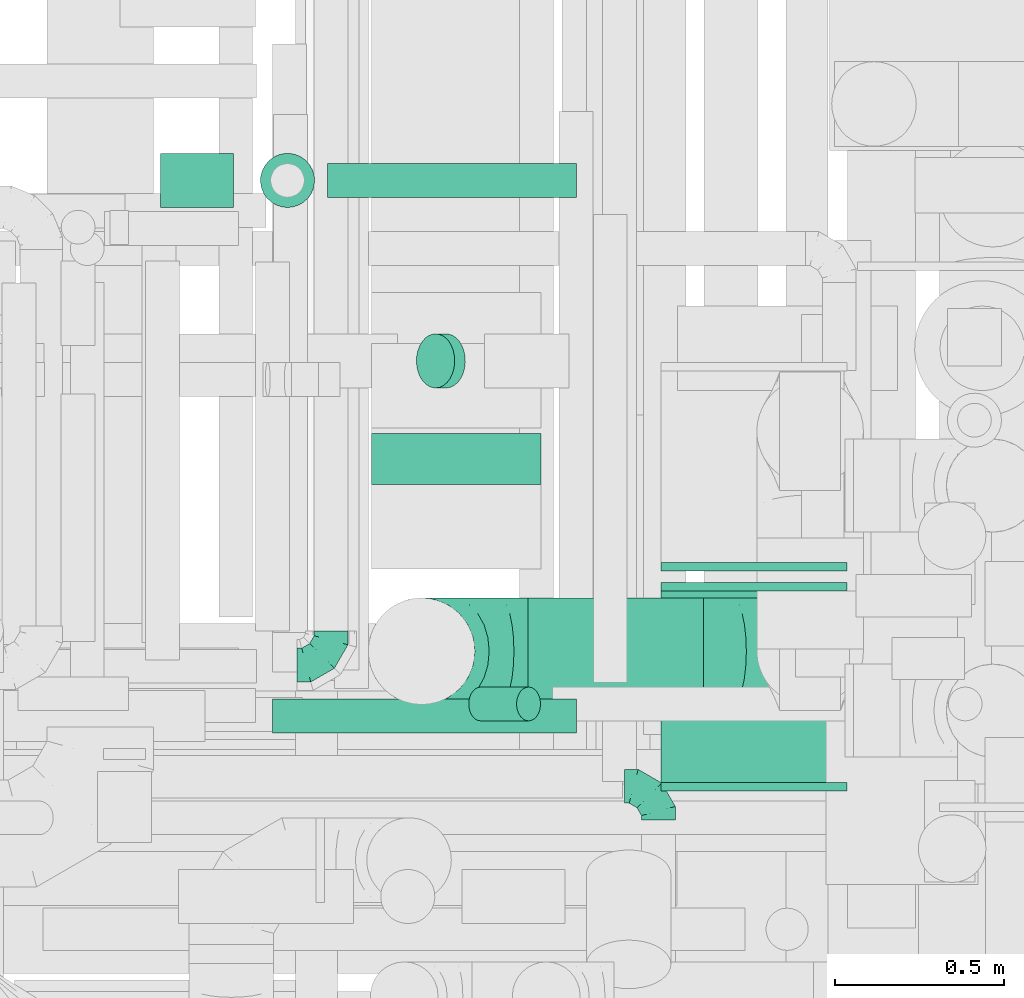
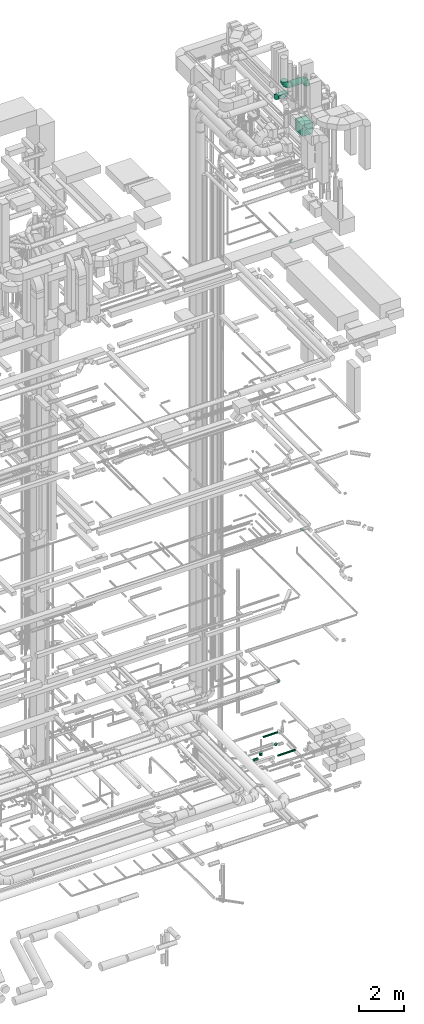
# One storey, part 302 of 337: 8 flow fittings, 8 flow segments.
"""IFC2X3 building model written with IfcOpenShell, lengths in millimetres."""

import ifcopenshell
import ifcopenshell.guid

model = None  # the IFC model being written
_history = None  # IfcOwnerHistory: only IFC2X3 demands one
_inside = {}  # id of a spatial element -> (the spatial element, [elements in it])
_under = {}  # id of a project, library or spatial element -> (it, [spatial elements below it])
_declared = {}  # id of a project -> (the project, [libraries it declares])
_typed = {}  # id of a type object -> (the type object, [elements of that type])
_made_of = {}  # id of a material, layer set ... -> (it, [elements and type objects made of it])


def new_model(schema):
    """Start an empty IFC model of exactly this schema.

    Asked for "IFC4X3", IfcOpenShell would pick the latest addendum, in which some entities
    have other attributes; the version numbers below select the first issue.
    IFC2X3 requires an IfcOwnerHistory on every rooted entity: one is made here for all.
    """
    global model, _history
    if schema == "IFC4X3":
        model = ifcopenshell.file(schema_version=(4, 3, 0, 0))
    else:
        model = ifcopenshell.file(schema=schema)
    _inside.clear()
    _under.clear()
    _declared.clear()
    _typed.clear()
    _made_of.clear()
    _history = None
    if model.schema == "IFC2X3":
        org = make("IfcOrganization", Name="unknown")
        user = make(
            "IfcPersonAndOrganization",
            ThePerson=make("IfcPerson", FamilyName="unknown"),
            TheOrganization=org,
        )
        app = make(
            "IfcApplication",
            ApplicationDeveloper=org,
            Version="unknown",
            ApplicationFullName="unknown",
            ApplicationIdentifier="unknown",
        )
        _history = make(
            "IfcOwnerHistory",
            OwningUser=user,
            OwningApplication=app,
            ChangeAction="ADDED",
            CreationDate=0,
        )
    return model


def make(cls, **values):
    """One entity of the class cls with the attributes given. An attribute that is None is left unset."""
    return model.create_entity(
        cls, **{name: value for name, value in values.items() if value is not None}
    )


def entity(cls, *values):
    """Any entity or typed value of the class cls, its attributes in the order of the schema. None: left unset."""
    e = model.create_entity(cls)
    for i, value in enumerate(values):
        if value is not None:
            e[i] = value
    return e


def rooted(cls, **values):
    """An entity with a GlobalId (a new one), such as an element, a storey or a relation."""
    return make(cls, GlobalId=ifcopenshell.guid.new(), OwnerHistory=_history, **values)


def si_unit(unit_type, name, prefix=None):
    """IfcSIUnit, for example si_unit("LENGTHUNIT", "METRE", prefix="MILLI")."""
    return make("IfcSIUnit", UnitType=unit_type, Prefix=prefix, Name=name)


def converted_unit(unit_type, name, factor, base, dimensions=None, offset=None):
    """IfcConversionBasedUnit, such as the inch: factor (a typed value) times the base unit."""
    return make(
        "IfcConversionBasedUnit"
        if offset is None
        else "IfcConversionBasedUnitWithOffset",
        ConversionOffset=offset,
        Dimensions=None
        if dimensions is None
        else entity("IfcDimensionalExponents", *dimensions),
        UnitType=unit_type,
        Name=name,
        ConversionFactor=make(
            "IfcMeasureWithUnit", ValueComponent=factor, UnitComponent=base
        ),
    )


def derived_unit(unit_type, elements):
    """IfcDerivedUnit: a product of units, each with its exponent."""
    return make(
        "IfcDerivedUnit",
        Elements=[
            make("IfcDerivedUnitElement", Unit=unit, Exponent=power)
            for unit, power in elements
        ],
        UnitType=unit_type,
    )


def assignment(units):
    """IfcUnitAssignment: the units of a project."""
    return None if units is None else make("IfcUnitAssignment", Units=units)


def point(xyz):
    """IfcCartesianPoint."""
    return None if xyz is None else make("IfcCartesianPoint", Coordinates=xyz)


def direction(xyz):
    """IfcDirection."""
    return None if xyz is None else make("IfcDirection", DirectionRatios=xyz)


def frame(location, z_axis=None, x_axis=None):
    """IfcAxis2Placement3D, a coordinate frame: its origin and axes. An axis left out is left unset."""
    return make(
        "IfcAxis2Placement3D",
        Location=point(location),
        Axis=direction(z_axis),
        RefDirection=direction(x_axis),
    )


def frame_2d(location, x_axis=None):
    """IfcAxis2Placement2D, a coordinate frame in the plane: its origin and x axis."""
    return make(
        "IfcAxis2Placement2D", Location=point(location), RefDirection=direction(x_axis)
    )


def origin():
    """The frame at (0, 0, 0) with its axes left unset."""
    return frame((0.0, 0.0, 0.0))


def origin_2d_with_axis():
    """The frame at (0, 0) in the plane with the x axis (1, 0) written out."""
    return frame_2d((0.0, 0.0), x_axis=(1.0, 0.0))


def place(relative_to, where):
    """IfcLocalPlacement: puts the frame where relative to a parent placement (None: the world)."""
    return make(
        "IfcLocalPlacement", PlacementRelTo=relative_to, RelativePlacement=where
    )


def context(
    kind, dimensions, precision=None, world=None, true_north=None, identifier=None
):
    """IfcGeometricRepresentationContext, for example the 3D "Model" context."""
    return make(
        "IfcGeometricRepresentationContext",
        ContextIdentifier=identifier,
        ContextType=kind,
        CoordinateSpaceDimension=dimensions,
        Precision=precision,
        WorldCoordinateSystem=world,
        TrueNorth=true_north,
    )


def subcontext(parent, identifier, kind, view, scale=None):
    """IfcGeometricRepresentationSubContext, for example "Body" below "Model"."""
    return make(
        "IfcGeometricRepresentationSubContext",
        ContextIdentifier=identifier,
        ContextType=kind,
        ParentContext=parent,
        TargetScale=scale,
        TargetView=view,
    )


def project(units=None, contexts=None):
    """IfcProject with its units and contexts."""
    return rooted(
        "IfcProject",
        Name="project",
        RepresentationContexts=contexts,
        UnitsInContext=assignment(units),
    )


def spatial(cls, under=None, at=None, **own):
    """A site, building, storey or space (cls), placed at a placement, below another one or the project."""
    s = rooted(cls, ObjectPlacement=at, **own)
    if under is not None:
        _under.setdefault(under.id(), (under, []))[1].append(s)
    return s


def polyline(points):
    """IfcPolyline through the points."""
    return make("IfcPolyline", Points=[point(p) for p in points])


def circle_curve(where, radius):
    """IfcCircle in the frame where."""
    return make("IfcCircle", Position=where, Radius=radius)


def parameter(value):
    """IfcParameterValue: where a trimmed curve begins or ends, as a parameter of its basis curve."""
    return model.create_entity("IfcParameterValue", value)


def trimmed(basis, trim1, trim2, sense, master):
    """IfcTrimmedCurve: the piece of a basis curve between two trims."""
    return make(
        "IfcTrimmedCurve",
        BasisCurve=basis,
        Trim1=trim1,
        Trim2=trim2,
        SenseAgreement=sense,
        MasterRepresentation=master,
    )


def segment(curve, same_sense, transition):
    """IfcCompositeCurveSegment."""
    return make(
        "IfcCompositeCurveSegment",
        Transition=transition,
        SameSense=same_sense,
        ParentCurve=curve,
    )


def composite_curve(segments, self_intersect=None):
    """IfcCompositeCurve: segments joined end to end."""
    return make("IfcCompositeCurve", Segments=segments, SelfIntersect=self_intersect)


def profile(cls, at=None, kind="AREA", **sizes):
    """A parametric profile (cls). Its sizes go by their IFC names, for example OverallWidth=200.0."""
    return make(cls, ProfileType=kind, Position=at, **sizes)


def rectangle(**sizes):
    """IfcRectangleProfileDef."""
    return profile("IfcRectangleProfileDef", **sizes)


def circle(**sizes):
    """IfcCircleProfileDef."""
    return profile("IfcCircleProfileDef", **sizes)


def outline(outer, holes=None, kind="AREA"):
    """IfcArbitraryClosedProfileDef: a profile drawn as a closed curve; with holes, ...WithVoids."""
    if holes is None:
        return make("IfcArbitraryClosedProfileDef", ProfileType=kind, OuterCurve=outer)
    return make(
        "IfcArbitraryProfileDefWithVoids",
        ProfileType=kind,
        OuterCurve=outer,
        InnerCurves=holes,
    )


def extrude(swept, where, along, depth):
    """IfcExtrudedAreaSolid: the profile swept, set in the frame where, extruded along a direction by depth."""
    return make(
        "IfcExtrudedAreaSolid",
        SweptArea=swept,
        Position=where,
        ExtrudedDirection=direction(along),
        Depth=depth,
    )


def faces_of(points, faces, orient=None, outer=None):
    """IfcFace entities. A face is a list of loops; a loop is a list of indices into points, from 0.

    orient and outer hold one flag for each loop. By default every Orientation is true, the
    first loop of a face is its IfcFaceOuterBound and the others are IfcFaceBound.
    """
    made = []
    for i, loops in enumerate(faces):
        bounds = []
        for j, loop in enumerate(loops):
            is_outer = j == 0 if outer is None else outer[i][j]
            bounds.append(
                make(
                    "IfcFaceOuterBound" if is_outer else "IfcFaceBound",
                    Bound=make("IfcPolyLoop", Polygon=[points[k] for k in loop]),
                    Orientation=True if orient is None else orient[i][j],
                )
            )
        made.append(make("IfcFace", Bounds=bounds))
    return made


def faceted_brep(points, faces, orient=None, outer=None, voids=None):
    """IfcFacetedBrep: a solid bounded by flat faces; with voids (closed shells), ...WithVoids."""
    shared = [point(p) for p in points]
    hull = make("IfcClosedShell", CfsFaces=faces_of(shared, faces, orient, outer))
    if voids is None:
        return make("IfcFacetedBrep", Outer=hull)
    return make(
        "IfcFacetedBrepWithVoids",
        Outer=hull,
        Voids=[
            make(cls, CfsFaces=faces_of(shared, fs, o, b)) for cls, fs, o, b in voids
        ],
    )


def shape(context_of_items, identifier, shape_type, items):
    """IfcShapeRepresentation: the items that make up one representation, for example the "Body"."""
    return make(
        "IfcShapeRepresentation",
        ContextOfItems=context_of_items,
        RepresentationIdentifier=identifier,
        RepresentationType=shape_type,
        Items=items,
    )


def source(mapping_origin, context_of_items, identifier, shape_type, items):
    """IfcRepresentationMap: a shape defined once, which mapped items show again and again."""
    return make(
        "IfcRepresentationMap",
        MappingOrigin=mapping_origin,
        MappedRepresentation=shape(context_of_items, identifier, shape_type, items),
    )


def transform(
    local_origin,
    x_axis=None,
    y_axis=None,
    z_axis=None,
    scale=None,
    scale2=None,
    scale3=None,
    uniform=True,
):
    """IfcCartesianTransformationOperator3D, or its non-uniform kind. x_axis, y_axis, z_axis: its Axis1, 2, 3."""
    if uniform:
        return make(
            "IfcCartesianTransformationOperator3D",
            Axis1=direction(x_axis),
            Axis2=direction(y_axis),
            LocalOrigin=point(local_origin),
            Scale=scale,
            Axis3=direction(z_axis),
        )
    return make(
        "IfcCartesianTransformationOperator3DnonUniform",
        Axis1=direction(x_axis),
        Axis2=direction(y_axis),
        LocalOrigin=point(local_origin),
        Scale=scale,
        Axis3=direction(z_axis),
        Scale2=scale2,
        Scale3=scale3,
    )


def mapped(mapping_source, mapping_target):
    """IfcMappedItem: shows the shape of a source again, moved by a transform."""
    return make(
        "IfcMappedItem", MappingSource=mapping_source, MappingTarget=mapping_target
    )


def material(Name=None, Category=None):
    """IfcMaterial."""
    return make("IfcMaterial", Name=Name, Category=Category)


def made_of(thing, what):
    """Note that an element or type object is made of a material, layer set ...; save() writes the relation."""
    if what is not None:
        _made_of.setdefault(what.id(), (what, []))[1].append(thing)
    return thing


def type_object(cls, material=None, **own):
    """A type object (cls), such as IfcWallType, which elements share."""
    return made_of(rooted(cls, **own), material)


def type_shapes(of_type, sources):
    """Give a type object the sources (RepresentationMaps) that its elements show as mapped items."""
    of_type.RepresentationMaps = sources


def element(
    cls,
    number,
    at=None,
    inside=None,
    cuts=None,
    type_object=None,
    material=None,
    context=None,
    identifier="Body",
    shape_type=None,
    held_by="IfcProductDefinitionShape",
    body=None,
    shapes=None,
    **own,
):
    """One element of the class cls, such as IfcWall. Its Tag is "e" and its number.

    at: its placement. inside: the storey or other place that contains it. cuts: it is an
    opening in that element (IfcRelVoidsElement). A single representation is given by context,
    identifier, shape_type and body (its items); several are given by shapes. held_by: the class
    of the entity that holds the representations. save() writes the other relations.
    """
    e = rooted(cls, Tag="e%d" % number, ObjectPlacement=at, **own)
    if body is not None:
        shapes = [shape(context, identifier, shape_type, body)]
    if shapes is not None:
        e.Representation = make(held_by, Representations=shapes)
    if inside is not None:
        _inside.setdefault(inside.id(), (inside, []))[1].append(e)
    if cuts is not None:
        rooted(
            "IfcRelVoidsElement", RelatingBuildingElement=cuts, RelatedOpeningElement=e
        )
    if type_object is not None:
        _typed.setdefault(type_object.id(), (type_object, []))[1].append(e)
    return made_of(e, material)


def aggregate(whole, parts):
    """IfcRelAggregates: a whole, such as a stair, and the parts it consists of."""
    return rooted("IfcRelAggregates", RelatingObject=whole, RelatedObjects=parts)


def save(model, path):
    """Write the relations noted so far, then the file.

    IfcRelAggregates (storeys below a building ...), IfcRelContainedInSpatialStructure (elements
    in a storey), IfcRelDefinesByType, IfcRelAssociatesMaterial and IfcRelDeclares: one each for
    every whole, place, type object, material and project.
    """
    for whole, parts in _under.values():
        aggregate(whole, parts)
    for where, things in _inside.values():
        rooted(
            "IfcRelContainedInSpatialStructure",
            RelatedElements=things,
            RelatingStructure=where,
        )
    for kind, things in _typed.values():
        rooted("IfcRelDefinesByType", RelatedObjects=things, RelatingType=kind)
    for what, things in _made_of.values():
        rooted("IfcRelAssociatesMaterial", RelatedObjects=things, RelatingMaterial=what)
    for by, libraries in _declared.values():
        rooted("IfcRelDeclares", RelatingContext=by, RelatedDefinitions=libraries)
    model.write(path)


model = new_model("IFC2X3")

# Units and contexts
model_context = context("Model", 3, precision=0.01, world=origin(), true_north=direction((6.12303176911189e-17, 1.0)))
body_context = subcontext(model_context, "Body", "Model", "MODEL_VIEW")
ifc_project = project(units=[si_unit("LENGTHUNIT", "METRE", prefix="MILLI"), si_unit("AREAUNIT", "SQUARE_METRE"), si_unit("VOLUMEUNIT", "CUBIC_METRE"), converted_unit("PLANEANGLEUNIT", "DEGREE", entity("IfcRatioMeasure", 0.0174532925199433), si_unit("PLANEANGLEUNIT", "RADIAN"), dimensions=[0, 0, 0, 0, 0, 0, 0]), si_unit("MASSUNIT", "GRAM", prefix="KILO"), derived_unit("MASSDENSITYUNIT", [(si_unit("MASSUNIT", "GRAM", prefix="KILO"), 1), (si_unit("LENGTHUNIT", "METRE"), -3)]), derived_unit("MOMENTOFINERTIAUNIT", [(si_unit("LENGTHUNIT", "METRE"), 4)]), si_unit("TIMEUNIT", "SECOND"), si_unit("FREQUENCYUNIT", "HERTZ"), si_unit("THERMODYNAMICTEMPERATUREUNIT", "DEGREE_CELSIUS"), derived_unit("THERMALTRANSMITTANCEUNIT", [(si_unit("MASSUNIT", "GRAM", prefix="KILO"), 1), (si_unit("THERMODYNAMICTEMPERATUREUNIT", "KELVIN"), -1), (si_unit("TIMEUNIT", "SECOND"), -3)]), derived_unit("VOLUMETRICFLOWRATEUNIT", [(si_unit("LENGTHUNIT", "METRE"), 3), (si_unit("TIMEUNIT", "SECOND"), -1)]), derived_unit("MASSFLOWRATEUNIT", [(si_unit("MASSUNIT", "GRAM", prefix="KILO"), 1), (si_unit("TIMEUNIT", "SECOND"), -1)]), derived_unit("ROTATIONALFREQUENCYUNIT", [(si_unit("TIMEUNIT", "SECOND"), -1)]), si_unit("ELECTRICCURRENTUNIT", "AMPERE"), si_unit("ELECTRICVOLTAGEUNIT", "VOLT"), si_unit("POWERUNIT", "WATT"), si_unit("FORCEUNIT", "NEWTON", prefix="KILO"), si_unit("ILLUMINANCEUNIT", "LUX"), si_unit("LUMINOUSFLUXUNIT", "LUMEN"), si_unit("LUMINOUSINTENSITYUNIT", "CANDELA"), derived_unit("USERDEFINED", [(si_unit("MASSUNIT", "GRAM", prefix="KILO"), -1), (si_unit("LENGTHUNIT", "METRE"), -2), (si_unit("TIMEUNIT", "SECOND"), 3), (si_unit("LUMINOUSFLUXUNIT", "LUMEN"), 1)]), derived_unit("LINEARVELOCITYUNIT", [(si_unit("LENGTHUNIT", "METRE"), 1), (si_unit("TIMEUNIT", "SECOND"), -1)]), si_unit("PRESSUREUNIT", "PASCAL"), derived_unit("USERDEFINED", [(si_unit("LENGTHUNIT", "METRE"), -2), (si_unit("MASSUNIT", "GRAM", prefix="KILO"), 1), (si_unit("TIMEUNIT", "SECOND"), -2)]), derived_unit("LINEARFORCEUNIT", [(si_unit("MASSUNIT", "GRAM", prefix="KILO"), 1), (si_unit("LENGTHUNIT", "METRE"), 1), (si_unit("TIMEUNIT", "SECOND"), -2), (si_unit("LENGTHUNIT", "METRE"), -1)]), derived_unit("PLANARFORCEUNIT", [(si_unit("MASSUNIT", "GRAM", prefix="KILO"), 1), (si_unit("LENGTHUNIT", "METRE"), 1), (si_unit("TIMEUNIT", "SECOND"), -2), (si_unit("LENGTHUNIT", "METRE"), -2)])], contexts=[model_context])

# Site, building, storey
site_placement = place(None, origin())
site = spatial("IfcSite", under=ifc_project, at=site_placement, CompositionType="ELEMENT")
building_placement = place(site_placement, origin())
building = spatial("IfcBuilding", under=site, at=building_placement, CompositionType="ELEMENT")
storey_placement = place(building_placement, origin())
storey = spatial("IfcBuildingStorey", under=building, at=storey_placement, CompositionType="ELEMENT", Elevation=0.0)

# Flow segments
duct_segment_type_1 = type_object("IfcDuctSegmentType", PredefinedType="NOTDEFINED")
flow_segment_1_placement = place(storey_placement, frame((71761.99, 9978.09, 32875.0)))
element("IfcFlowSegment", 1, at=flow_segment_1_placement, inside=storey, type_object=duct_segment_type_1, context=body_context, shape_type="SweptSolid", body=[
    extrude(rectangle(XDim=564.999999999999, YDim=549.999999999996, at=origin_2d_with_axis()), frame((275.0, 282.5, 0.0), z_axis=(0.0, 0.0, 1.0), x_axis=(0.0, 1.0, 0.0)), (0.0, 0.0, 1.0), 600.000000000002),
])
duct_segment_type_2 = type_object("IfcDuctSegmentType", PredefinedType="NOTDEFINED")
flow_segment_2_placement = place(storey_placement, frame((71038.37, 11141.98, -811.3)))
element("IfcFlowSegment", 2, at=flow_segment_2_placement, inside=storey, type_object=duct_segment_type_2, context=body_context, shape_type="SweptSolid", body=[
    extrude(circle(Radius=80.0, at=origin_2d_with_axis()), frame((89.44, 81.6, 58.16), z_axis=(-0.707106781186528, 0.0, 0.707106781186567), x_axis=(0.0, -1.0, 0.0)), (0.0, 0.0, 1.0), 44.2283553372559),
])
flow_segment_3_placement = place(storey_placement, frame((70615.27, 10122.47, -601.6)))
element("IfcFlowSegment", 3, at=flow_segment_3_placement, inside=storey, type_object=duct_segment_type_2, context=body_context, shape_type="SweptSolid", body=[
    extrude(circle(Radius=50.0, at=origin_2d_with_axis()), frame((0.0, 51.6, 51.6), z_axis=(1.0, 0.0, 0.0), x_axis=(0.0, -1.0, 0.0)), (0.0, 0.0, 1.0), 897.35598),
])
flow_segment_4_placement = place(storey_placement, frame((70776.87, 11705.15, -601.6)))
element("IfcFlowSegment", 4, at=flow_segment_4_placement, inside=storey, type_object=duct_segment_type_2, context=body_context, shape_type="SweptSolid", body=[
    extrude(circle(Radius=50.0, at=origin_2d_with_axis()), frame((0.0, 51.6, 51.6), z_axis=(1.0, 1.88958848521519e-05, 0.0), x_axis=(-1.88958848521519e-05, 1.0, 0.0)), (0.0, 0.0, 1.0), 735.759095522448),
])
flow_segment_5_placement = place(storey_placement, frame((70577.43, 11675.14, -1493.0)))
element("IfcFlowSegment", 5, at=flow_segment_5_placement, inside=storey, type_object=duct_segment_type_2, context=body_context, shape_type="SweptSolid", body=[
    extrude(circle(Radius=80.0, at=origin_2d_with_axis()), frame((81.6, 81.6, 0.0), z_axis=(0.0, 0.0, 1.0), x_axis=(0.0, -1.0, 0.0)), (0.0, 0.0, 1.0), 137.00889525),
])
flow_segment_6_placement = place(storey_placement, frame((70284.02, 11675.14, -1734.6)))
element("IfcFlowSegment", 6, at=flow_segment_6_placement, inside=storey, type_object=duct_segment_type_2, context=body_context, shape_type="SweptSolid", body=[
    extrude(circle(Radius=80.0, at=origin_2d_with_axis()), frame((0.0, 81.6, 81.6), z_axis=(1.0, 0.0, 0.0), x_axis=(0.0, 1.0, 0.0)), (0.0, 0.0, 1.0), 215.000000000012),
])
flow_segment_7_placement = place(storey_placement, frame((71370.26, 10206.55, 35480.9)))
element("IfcFlowSegment", 7, at=flow_segment_7_placement, inside=storey, type_object=duct_segment_type_2, context=body_context, shape_type="SweptSolid", body=[
    extrude(circle(Radius=157.5, at=origin_2d_with_axis()), frame((0.0, 159.1, 159.1), z_axis=(1.0, 0.0, 0.0), x_axis=(0.0, -1.0, 0.0)), (0.0, 0.0, 1.0), 517.852389623369),
])
flow_segment_8_placement = place(storey_placement, frame((71192.83, 10158.38, 27112.34)))
element("IfcFlowSegment", 8, at=flow_segment_8_placement, inside=storey, type_object=duct_segment_type_2, context=body_context, shape_type="SweptSolid", body=[
    extrude(circle(Radius=50.0, at=origin_2d_with_axis()), frame((36.95, 51.6, 36.95), z_axis=(0.707106781186548, 0.0, 0.707106781186548), x_axis=(0.0, -1.0, 0.0)), (0.0, 0.0, 1.0), 200.000000000001),
])

# Flow fittings
ifc_material = material()
duct_fitting_type_1 = type_object("IfcDuctFittingType", PredefinedType="NOTDEFINED", material=ifc_material)
shared_shape_1 = source(origin(), body_context, "Body", "SweptSolid", [
    extrude(rectangle(XDim=24.9999999999999, YDim=550.0, at=origin_2d_with_axis()), frame((12.5, 0.0, -300.0)), (0.0, 0.0, 1.0), 600.0),
])
type_shapes(duct_fitting_type_1, [shared_shape_1])
for number, where, z_axis, x_axis in (
    (9, (72036.99, 10628.09, 33175.0), (0.0, 0.0, 1.0), (0.0, -1.0, 0.0)),
    (10, (72036.99, 9978.09, 33175.0), (0.0, 0.0, 1.0), (0.0, -1.0, 0.0)),
    (11, (72036.99, 10543.09, 33175.0), (0.0, 0.0, 1.0), (0.0, 1.0, 0.0)),
):
    element("IfcFlowFitting", number, at=place(storey_placement, frame(where, z_axis=z_axis, x_axis=x_axis)), inside=storey, type_object=duct_fitting_type_1, material=ifc_material, context=body_context, shape_type="MappedRepresentation", body=[
        mapped(shared_shape_1, transform((0.0, 0.0, 0.0), scale=1.0)),
    ])
duct_fitting_type_2 = type_object("IfcDuctFittingType", PredefinedType="NOTDEFINED", material=ifc_material)
shared_shape_2 = source(origin(), body_context, "Body", "Brep", [
    faceted_brep([(-100.0, 0.0, -50.0), (-100.0, -12.94, -48.3), (-100.0, -25.0, -43.3), (-100.0, -35.36, -35.36), (-100.0, -43.3, -25.0), (-100.0, -48.3, -12.94), (-100.0, -50.0, 0.0), (-100.0, -48.3, 12.94), (-100.0, -43.3, 25.0), (-100.0, -35.36, 35.36), (-100.0, -25.0, 43.3), (-100.0, -12.94, 48.3), (-100.0, 0.0, 50.0), (-100.0, 12.94, 48.3), (-100.0, 25.0, 43.3), (-100.0, 35.36, 35.36), (-100.0, 43.3, 25.0), (-100.0, 48.3, 12.94), (-100.0, 50.0, 0.0), (-100.0, 48.3, -12.94), (-100.0, 43.3, -25.0), (-100.0, 35.36, -35.36), (-100.0, 25.0, -43.3), (-100.0, 12.94, -48.3), (-76.67, 12.94, 48.3), (-79.9, 25.0, 43.3), (-73.21, 0.0, 50.0), (-82.68, 35.36, 35.36), (-86.15, 48.3, 12.94), (-86.6, 50.0, 0.0), (-84.81, 43.3, 25.0), (-84.81, 43.3, -25.0), (-82.68, 35.36, -35.36), (-86.15, 48.3, -12.94), (-76.67, 12.94, -48.3), (-73.21, 0.0, -50.0), (-79.9, 25.0, -43.3), (-69.74, -12.94, -48.3), (-66.51, -25.0, -43.3), (-63.73, -35.36, -35.36), (-61.6, -43.3, -25.0), (-60.26, -48.3, -12.94), (-59.81, -50.0, 0.0), (-60.26, -48.3, 12.94), (-61.6, -43.3, 25.0), (-63.73, -35.36, 35.36), (-66.51, -25.0, 43.3), (-69.74, -12.94, 48.3), (-36.27, 36.27, 48.3), (-45.1, 45.1, 43.3), (-26.79, 26.79, 50.0), (-52.68, 52.68, 35.36), (-58.49, 58.49, 25.0), (-62.15, 62.15, 12.94), (-63.4, 63.4, 0.0), (-62.15, 62.15, -12.94), (-58.49, 58.49, -25.0), (-52.68, 52.68, -35.36), (-36.27, 36.27, -48.3), (-26.79, 26.79, -50.0), (-45.1, 45.1, -43.3), (-17.32, 17.32, -48.3), (-8.49, 8.49, -43.3), (-0.91, 0.91, -35.36), (4.9, -4.9, -25.0), (8.56, -8.56, -12.94), (9.81, -9.81, 0.0), (8.56, -8.56, 12.94), (4.9, -4.9, 25.0), (-0.91, 0.91, 35.36), (-8.49, 8.49, 43.3), (-17.32, 17.32, 48.3), (-12.94, 76.67, 48.3), (-25.0, 79.9, 43.3), (0.0, 73.21, 50.0), (-35.36, 82.68, 35.36), (-43.3, 84.81, 25.0), (-48.3, 86.15, 12.94), (-50.0, 86.6, 0.0), (-48.3, 86.15, -12.94), (-43.3, 84.81, -25.0), (-35.36, 82.68, -35.36), (-12.94, 76.67, -48.3), (0.0, 73.21, -50.0), (-25.0, 79.9, -43.3), (12.94, 69.74, -48.3), (25.0, 66.51, -43.3), (35.36, 63.73, -35.36), (43.3, 61.6, -25.0), (48.3, 60.26, -12.94), (50.0, 59.81, 0.0), (48.3, 60.26, 12.94), (43.3, 61.6, 25.0), (35.36, 63.73, 35.36), (25.0, 66.51, 43.3), (12.94, 69.74, 48.3), (-12.94, 100.0, -48.3), (-25.0, 100.0, -43.3), (-35.36, 100.0, -35.36), (-43.3, 100.0, -25.0), (-48.3, 100.0, -12.94), (-50.0, 100.0, 0.0), (-48.3, 100.0, 12.94), (-43.3, 100.0, 25.0), (-35.36, 100.0, 35.36), (-25.0, 100.0, 43.3), (-12.94, 100.0, 48.3), (0.0, 100.0, 50.0), (12.94, 100.0, 48.3), (25.0, 100.0, 43.3), (35.36, 100.0, 35.36), (43.3, 100.0, 25.0), (48.3, 100.0, 12.94), (50.0, 100.0, 0.0), (48.3, 100.0, -12.94), (43.3, 100.0, -25.0), (35.36, 100.0, -35.36), (25.0, 100.0, -43.3), (12.94, 100.0, -48.3), (0.0, 100.0, -50.0)], [[[0, 1, 2, 3, 4, 5, 6, 7, 8, 9, 10, 11, 12, 13, 14, 15, 16, 17, 18, 19, 20, 21, 22, 23]], [[24, 25, 14, 13]], [[26, 24, 13, 12]], [[14, 25, 27, 15]], [[28, 29, 18, 17]], [[30, 28, 17, 16]], [[15, 27, 30, 16]], [[20, 31, 32, 21]], [[33, 31, 20, 19]], [[18, 29, 33, 19]], [[34, 35, 0, 23]], [[36, 34, 23, 22]], [[32, 36, 22, 21]], [[2, 1, 37, 38]], [[3, 2, 38, 39]], [[0, 35, 37, 1]], [[5, 4, 40, 41]], [[6, 5, 41, 42]], [[3, 39, 40, 4]], [[6, 42, 43, 7]], [[7, 43, 44, 8]], [[8, 44, 45, 9]], [[10, 46, 47, 11]], [[11, 47, 26, 12]], [[10, 9, 45, 46]], [[48, 49, 25, 24]], [[50, 48, 24, 26]], [[27, 25, 49, 51]], [[52, 53, 28, 30]], [[51, 52, 30, 27]], [[29, 28, 53, 54]], [[55, 56, 31, 33]], [[54, 55, 33, 29]], [[57, 32, 31, 56]], [[58, 59, 35, 34]], [[60, 58, 34, 36]], [[57, 60, 36, 32]], [[37, 35, 59, 61]], [[38, 37, 61, 62]], [[39, 38, 62, 63]], [[41, 40, 64, 65]], [[42, 41, 65, 66]], [[63, 64, 40, 39]], [[43, 42, 66, 67]], [[44, 43, 67, 68]], [[68, 69, 45, 44]], [[46, 45, 69, 70]], [[47, 46, 70, 71]], [[26, 47, 71, 50]], [[72, 73, 49, 48]], [[74, 72, 48, 50]], [[51, 49, 73, 75]], [[76, 77, 53, 52]], [[75, 76, 52, 51]], [[54, 53, 77, 78]], [[79, 80, 56, 55]], [[78, 79, 55, 54]], [[81, 57, 56, 80]], [[82, 83, 59, 58]], [[84, 82, 58, 60]], [[81, 84, 60, 57]], [[61, 59, 83, 85]], [[62, 61, 85, 86]], [[63, 62, 86, 87]], [[65, 64, 88, 89]], [[66, 65, 89, 90]], [[87, 88, 64, 63]], [[67, 66, 90, 91]], [[68, 67, 91, 92]], [[92, 93, 69, 68]], [[70, 69, 93, 94]], [[71, 70, 94, 95]], [[50, 71, 95, 74]], [[96, 97, 98, 99, 100, 101, 102, 103, 104, 105, 106, 107, 108, 109, 110, 111, 112, 113, 114, 115, 116, 117, 118, 119]], [[72, 74, 107, 106]], [[73, 72, 106, 105]], [[75, 73, 105, 104]], [[77, 76, 103, 102]], [[78, 77, 102, 101]], [[75, 104, 103, 76]], [[78, 101, 100, 79]], [[79, 100, 99, 80]], [[80, 99, 98, 81]], [[96, 119, 83, 82]], [[97, 96, 82, 84]], [[84, 81, 98, 97]], [[83, 119, 118, 85]], [[85, 118, 117, 86]], [[86, 117, 116, 87]], [[88, 115, 114, 89]], [[89, 114, 113, 90]], [[87, 116, 115, 88]], [[91, 90, 113, 112]], [[92, 91, 112, 111]], [[93, 92, 111, 110]], [[95, 94, 109, 108]], [[74, 95, 108, 107]], [[110, 109, 94, 93]]]),
])
type_shapes(duct_fitting_type_2, [shared_shape_2])
flow_fitting_1_placement = place(storey_placement, frame((70787.73, 10324.99, 3350.0)))
element("IfcFlowFitting", 12, at=flow_fitting_1_placement, inside=storey, type_object=duct_fitting_type_2, material=ifc_material, context=body_context, shape_type="MappedRepresentation", body=[
    mapped(shared_shape_2, transform((0.0, 0.0, 0.0), scale=1.0)),
])
flow_fitting_2_placement = place(storey_placement, frame((71754.89, 9966.79, 11520.0), z_axis=(0.0, 0.0, 1.0), x_axis=(0.0, 1.0, 0.0)))
element("IfcFlowFitting", 13, at=flow_fitting_2_placement, inside=storey, type_object=duct_fitting_type_2, material=ifc_material, context=body_context, shape_type="MappedRepresentation", body=[
    mapped(shared_shape_2, transform((0.0, 0.0, 0.0), scale=1.0)),
])
duct_fitting_type_3 = type_object("IfcDuctFittingType", PredefinedType="NOTDEFINED", material=ifc_material)
shared_shape_3 = source(origin(), body_context, "Body", "Brep", [
    faceted_brep([(-315.0, 0.0, -157.5), (-315.0, -40.76, -152.13), (-315.0, -78.75, -136.4), (-315.0, -111.37, -111.37), (-315.0, -136.4, -78.75), (-315.0, -152.13, -40.76), (-315.0, -157.5, 0.0), (-315.0, -152.13, 40.76), (-315.0, -136.4, 78.75), (-315.0, -111.37, 111.37), (-315.0, -78.75, 136.4), (-315.0, -40.76, 152.13), (-315.0, 0.0, 157.5), (-315.0, 40.76, 152.13), (-315.0, 78.75, 136.4), (-315.0, 111.37, 111.37), (-315.0, 136.4, 78.75), (-315.0, 152.13, 40.76), (-315.0, 157.5, 0.0), (-315.0, 152.13, -40.76), (-315.0, 136.4, -78.75), (-315.0, 111.37, -111.37), (-315.0, 78.75, -136.4), (-315.0, 40.76, -152.13), (-241.52, 40.76, 152.13), (-251.7, 78.75, 136.4), (-230.6, 0.0, 157.5), (-260.44, 111.37, 111.37), (-271.36, 152.13, 40.76), (-272.8, 157.5, 0.0), (-267.14, 136.4, 78.75), (-267.14, 136.4, -78.75), (-260.44, 111.37, -111.37), (-271.36, 152.13, -40.76), (-241.52, 40.76, -152.13), (-230.6, 0.0, -157.5), (-251.7, 78.75, -136.4), (-219.67, -40.76, -152.13), (-209.5, -78.75, -136.4), (-200.75, -111.37, -111.37), (-194.05, -136.4, -78.75), (-189.83, -152.13, -40.76), (-188.39, -157.5, 0.0), (-189.83, -152.13, 40.76), (-194.05, -136.4, 78.75), (-200.75, -111.37, 111.37), (-209.5, -78.75, 136.4), (-219.67, -40.76, 152.13), (-114.25, 114.25, 152.13), (-142.05, 142.05, 136.4), (-84.4, 84.4, 157.5), (-165.93, 165.93, 111.37), (-184.25, 184.25, 78.75), (-195.77, 195.77, 40.76), (-199.7, 199.7, 0.0), (-195.77, 195.77, -40.76), (-184.25, 184.25, -78.75), (-165.93, 165.93, -111.37), (-114.25, 114.25, -152.13), (-84.4, 84.4, -157.5), (-142.05, 142.05, -136.4), (-54.56, 54.56, -152.13), (-26.75, 26.75, -136.4), (-2.88, 2.88, -111.37), (15.45, -15.45, -78.75), (26.97, -26.97, -40.76), (30.89, -30.89, 0.0), (26.97, -26.97, 40.76), (15.45, -15.45, 78.75), (-2.88, 2.88, 111.37), (-26.75, 26.75, 136.4), (-54.56, 54.56, 152.13), (-40.76, 241.52, 152.13), (-78.75, 251.7, 136.4), (0.0, 230.6, 157.5), (-111.37, 260.44, 111.37), (-136.4, 267.14, 78.75), (-152.13, 271.36, 40.76), (-157.5, 272.8, 0.0), (-152.13, 271.36, -40.76), (-136.4, 267.14, -78.75), (-111.37, 260.44, -111.37), (-40.76, 241.52, -152.13), (0.0, 230.6, -157.5), (-78.75, 251.7, -136.4), (40.76, 219.67, -152.13), (78.75, 209.5, -136.4), (111.37, 200.75, -111.37), (136.4, 194.05, -78.75), (152.13, 189.83, -40.76), (157.5, 188.39, 0.0), (152.13, 189.83, 40.76), (136.4, 194.05, 78.75), (111.37, 200.75, 111.37), (78.75, 209.5, 136.4), (40.76, 219.67, 152.13), (-40.76, 315.0, -152.13), (-78.75, 315.0, -136.4), (-111.37, 315.0, -111.37), (-136.4, 315.0, -78.75), (-152.13, 315.0, -40.76), (-157.5, 315.0, 0.0), (-152.13, 315.0, 40.76), (-136.4, 315.0, 78.75), (-111.37, 315.0, 111.37), (-78.75, 315.0, 136.4), (-40.76, 315.0, 152.13), (0.0, 315.0, 157.5), (40.76, 315.0, 152.13), (78.75, 315.0, 136.4), (111.37, 315.0, 111.37), (136.4, 315.0, 78.75), (152.13, 315.0, 40.76), (157.5, 315.0, 0.0), (152.13, 315.0, -40.76), (136.4, 315.0, -78.75), (111.37, 315.0, -111.37), (78.75, 315.0, -136.4), (40.76, 315.0, -152.13), (0.0, 315.0, -157.5)], [[[0, 1, 2, 3, 4, 5, 6, 7, 8, 9, 10, 11, 12, 13, 14, 15, 16, 17, 18, 19, 20, 21, 22, 23]], [[24, 25, 14, 13]], [[26, 24, 13, 12]], [[14, 25, 27, 15]], [[28, 29, 18, 17]], [[30, 28, 17, 16]], [[15, 27, 30, 16]], [[20, 31, 32, 21]], [[33, 31, 20, 19]], [[18, 29, 33, 19]], [[34, 35, 0, 23]], [[36, 34, 23, 22]], [[32, 36, 22, 21]], [[1, 0, 35, 37]], [[2, 1, 37, 38]], [[38, 39, 3, 2]], [[5, 4, 40, 41]], [[6, 5, 41, 42]], [[39, 40, 4, 3]], [[6, 42, 43, 7]], [[7, 43, 44, 8]], [[8, 44, 45, 9]], [[9, 45, 46, 10]], [[10, 46, 47, 11]], [[26, 12, 11, 47]], [[48, 49, 25, 24]], [[50, 48, 24, 26]], [[27, 25, 49, 51]], [[52, 53, 28, 30]], [[51, 52, 30, 27]], [[29, 28, 53, 54]], [[55, 56, 31, 33]], [[54, 55, 33, 29]], [[32, 31, 56, 57]], [[58, 59, 35, 34]], [[60, 58, 34, 36]], [[57, 60, 36, 32]], [[37, 35, 59, 61]], [[38, 37, 61, 62]], [[39, 38, 62, 63]], [[41, 40, 64, 65]], [[42, 41, 65, 66]], [[63, 64, 40, 39]], [[43, 42, 66, 67]], [[44, 43, 67, 68]], [[68, 69, 45, 44]], [[46, 45, 69, 70]], [[47, 46, 70, 71]], [[26, 47, 71, 50]], [[72, 73, 49, 48]], [[74, 72, 48, 50]], [[51, 49, 73, 75]], [[76, 77, 53, 52]], [[75, 76, 52, 51]], [[54, 53, 77, 78]], [[79, 80, 56, 55]], [[78, 79, 55, 54]], [[57, 56, 80, 81]], [[82, 83, 59, 58]], [[84, 82, 58, 60]], [[81, 84, 60, 57]], [[61, 59, 83, 85]], [[62, 61, 85, 86]], [[63, 62, 86, 87]], [[65, 64, 88, 89]], [[66, 65, 89, 90]], [[87, 88, 64, 63]], [[67, 66, 90, 91]], [[68, 67, 91, 92]], [[92, 93, 69, 68]], [[70, 69, 93, 94]], [[71, 70, 94, 95]], [[50, 71, 95, 74]], [[96, 97, 98, 99, 100, 101, 102, 103, 104, 105, 106, 107, 108, 109, 110, 111, 112, 113, 114, 115, 116, 117, 118, 119]], [[106, 105, 73, 72]], [[107, 106, 72, 74]], [[75, 73, 105, 104]], [[77, 76, 103, 102]], [[78, 77, 102, 101]], [[104, 103, 76, 75]], [[78, 101, 100, 79]], [[79, 100, 99, 80]], [[98, 81, 80, 99]], [[84, 97, 96, 82]], [[82, 96, 119, 83]], [[97, 84, 81, 98]], [[83, 119, 118, 85]], [[85, 118, 117, 86]], [[116, 87, 86, 117]], [[88, 115, 114, 89]], [[89, 114, 113, 90]], [[115, 88, 87, 116]], [[91, 90, 113, 112]], [[92, 91, 112, 111]], [[111, 110, 93, 92]], [[95, 94, 109, 108]], [[74, 95, 108, 107]], [[110, 109, 94, 93]]]),
])
type_shapes(duct_fitting_type_3, [shared_shape_3])
for number, where, z_axis, x_axis in (
    (14, (71055.26, 10365.65, 35640.0), (0.0, -1.0, 0.0), (0.0, 0.0, -1.0)),
    (15, (72203.11, 10365.65, 35640.0), (0.0, -1.0, 0.0), (0.0, 0.0, 1.0)),
):
    element("IfcFlowFitting", number, at=place(storey_placement, frame(where, z_axis=z_axis, x_axis=x_axis)), inside=storey, type_object=duct_fitting_type_3, material=ifc_material, context=body_context, shape_type="MappedRepresentation", body=[
        mapped(shared_shape_3, transform((0.0, 0.0, 0.0), scale=1.0)),
    ])
duct_fitting_type_4 = type_object("IfcDuctFittingType", PredefinedType="NOTDEFINED", material=ifc_material)
shared_shape_4 = source(origin(), body_context, "Body", "SweptSolid", [
    extrude(outline(composite_curve([segment(polyline([(-262.5, -137.5), (-12.5, -137.5)]), True, "CONTINUOUS"), segment(trimmed(circle_curve(frame_2d((137.5, -137.5), x_axis=(0.0, 1.0)), 150.0), [parameter(0.0)], [parameter(90.0000000000001)], True, "PARAMETER"), False, "CONTINUOUS"), segment(polyline([(137.5, 12.5), (137.5, 262.5)]), True, "CONTINUOUS"), segment(trimmed(circle_curve(frame_2d((137.5, -137.5), x_axis=(0.0, 1.0)), 400.0), [parameter(0.0)], [parameter(90.0000000000001)], True, "PARAMETER"), True, "CONTINUOUS")], self_intersect=False)), frame((-137.5, 137.5, -250.0), z_axis=(0.0, 0.0, 1.0), x_axis=(-1.0, 0.0, 0.0)), (0.0, 0.0, 1.0), 500.0),
])
type_shapes(duct_fitting_type_4, [shared_shape_4])
flow_fitting_3_placement = place(storey_placement, frame((71157.48, 10733.7, 34725.0), z_axis=(-1.0, 0.0, 0.0), x_axis=(0.0, -1.0, 0.0)))
element("IfcFlowFitting", 16, at=flow_fitting_3_placement, inside=storey, type_object=duct_fitting_type_4, material=ifc_material, context=body_context, shape_type="MappedRepresentation", body=[
    mapped(shared_shape_4, transform((0.0, 0.0, 0.0), scale=1.0)),
])

save(model, "model.ifc")
